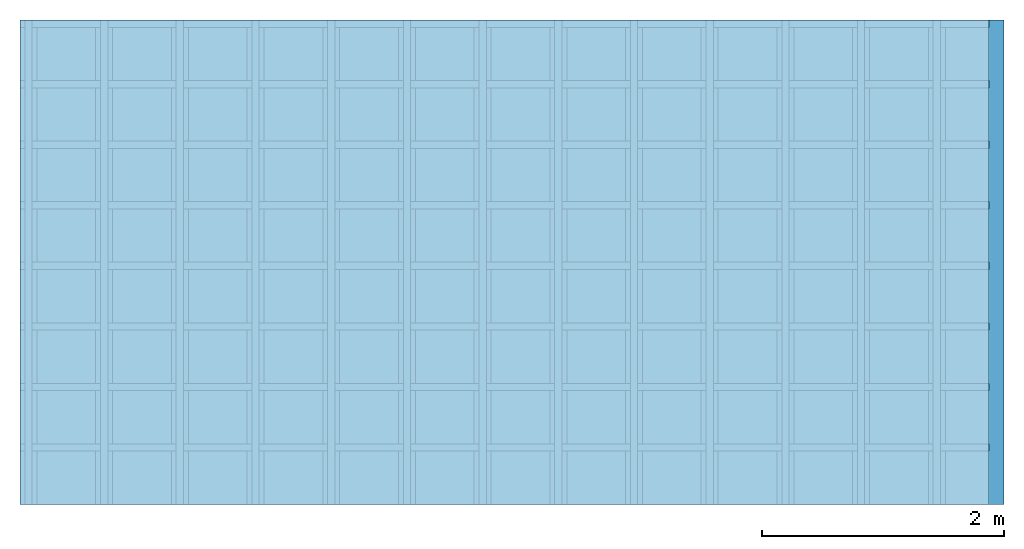
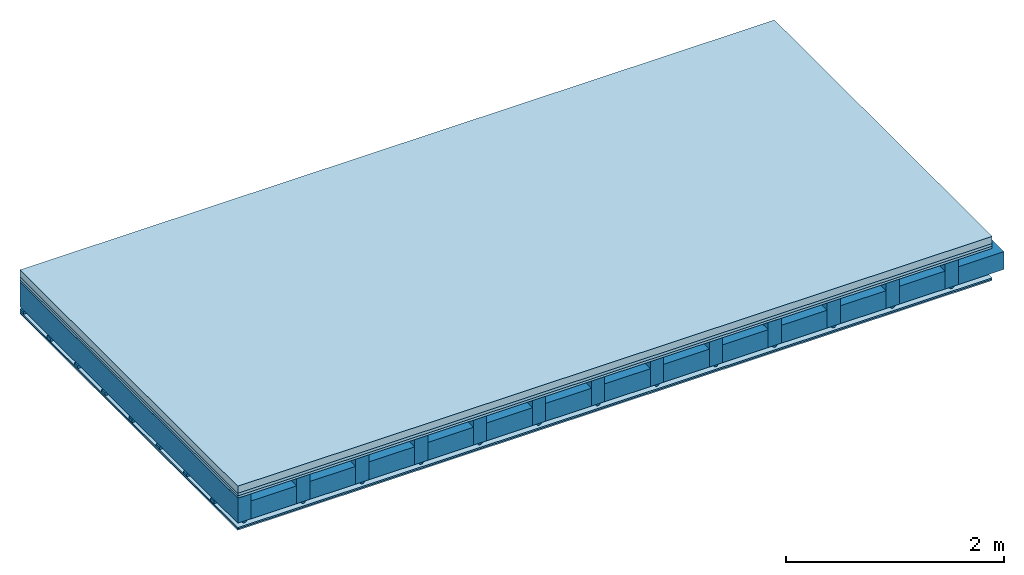
# One storey: 5 plates, 4 members, 1 element without a shape of its own.
"""IFC4 building model written with IfcOpenShell, lengths in metres."""

from ifc_helpers import new_model, si_unit, derived_unit, direction, frame, frame_2d, origin, origin_with_axes, place, context, project, spatial, polyline, rectangle, outline, extrude, material, layer, layer_set, type_object, element, aggregate, save


model = new_model("IFC4")

# Units and contexts
plan_context = context("Plan", 3, precision=1e-05, world=origin(), true_north=direction((0.0, 1.0)))
model_context = context("Model", 3, precision=1e-05, world=origin(), true_north=direction((0.0, 1.0)))
ifc_project = project(units=[si_unit("LENGTHUNIT", "METRE"), derived_unit("SOUNDPRESSUREUNIT", [(si_unit("PRESSUREUNIT", "PASCAL", prefix="MICRO"), 0)]), si_unit("ENERGYUNIT", "JOULE", prefix="MEGA"), si_unit("MASSUNIT", "GRAM", prefix="KILO"), derived_unit("THERMALTRANSMITTANCEUNIT", [(si_unit("POWERUNIT", "WATT"), 1), (si_unit("AREAUNIT", "SQUARE_METRE"), -1), (si_unit("THERMODYNAMICTEMPERATUREUNIT", "KELVIN"), -1)]), derived_unit("AREADENSITYUNIT", [(si_unit("MASSUNIT", "GRAM", prefix="KILO"), 1), (si_unit("AREAUNIT", "SQUARE_METRE"), -1)]), derived_unit("USERDEFINED", [(si_unit("ENERGYUNIT", "JOULE", prefix="MEGA"), 1), (si_unit("AREAUNIT", "SQUARE_METRE"), -1)])], contexts=[plan_context, model_context])

# Site, building, storey
site = spatial("IfcSite", under=ifc_project)
building_placement = place(None, origin())
building = spatial("IfcBuilding", under=site, at=building_placement)
storey_placement = place(building_placement, origin())
storey = spatial("IfcBuildingStorey", under=building, at=storey_placement)

# Slab, members, plates
ifc_material_1 = material(Name="Cement screed", Category="04.006")
ifc_layer_1 = layer(ifc_material_1, 0.08, Name="On-material")
ifc_material_2 = material()
ifc_layer_2 = layer(ifc_material_2, 0.03, Name="Impact sound insulation")
ifc_material_3 = material(Category="07.001")
ifc_layer_3 = layer(ifc_material_3, 0.025, Name="Sub-floor")
ifc_material_4 = material(Name="of the art")
ifc_layer_4 = layer(ifc_material_4, 0.0, Name="Bond")
ifc_layer_5 = layer(None, 0.28, Name="Supporting structure")
ifc_material_5 = material(Name="no composite action")
ifc_layer_6 = layer(ifc_material_5, 0.0, Name="Bond")
ifc_layer_7 = layer(None, 0.02, Name="Coupling")
ifc_layer_8 = layer(None, 0.03, Name="Battens / profiles")
ifc_material_6 = material(Category="03.007")
ifc_layer_9 = layer(ifc_material_6, 0.015, Name="Ceiling covering 1st layer")
ifc_layer_10 = layer(ifc_material_6, 0.015, Name="Ceiling covering layer 2")
ifc_material_7 = material(Name="Glued joints")
ifc_layer_11 = layer(ifc_material_7, 0.0, Name="Surface / treatment")
ifc_layer_set = layer_set([ifc_layer_1, ifc_layer_2, ifc_layer_3, ifc_layer_4, ifc_layer_5, ifc_layer_6, ifc_layer_7, ifc_layer_8, ifc_layer_9, ifc_layer_10, ifc_layer_11])
slab_type = type_object("IfcSlabType", Name="A0125", PredefinedType="NOTDEFINED", material=ifc_layer_set)
slab_placement = place(None, frame((0.0, 0.0, 0.0), z_axis=(0.0, 0.0, -1.0), x_axis=(1.0, 0.0, 0.0)))
slab = element("IfcSlab", 1, at=slab_placement, inside=storey, type_object=slab_type, material=ifc_layer_set, Name="Slab #1")
ifc_material_8 = material()
member_1_placement = place(slab_placement, origin())
member_1 = element("IfcMember", 2, at=member_1_placement, material=ifc_material_8, Name="Supporting structure", context=plan_context, shape_type="SweptSolid", body=[
    extrude(rectangle(XDim=0.14, YDim=0.28, at=frame_2d((0.07, 0.14), x_axis=(1.0, 0.0))), frame((0.0, 4.0, 0.135), z_axis=(0.0, -1.0, 0.0), x_axis=(1.0, 0.0, 0.0)), (0.0, 0.0, 1.0), 4.0),
    extrude(rectangle(XDim=0.14, YDim=0.28, at=frame_2d((0.07, 0.14), x_axis=(1.0, 0.0))), frame((0.625, 4.0, 0.135), z_axis=(0.0, -1.0, 0.0), x_axis=(1.0, 0.0, 0.0)), (0.0, 0.0, 1.0), 4.0),
    extrude(rectangle(XDim=0.14, YDim=0.28, at=frame_2d((0.07, 0.14), x_axis=(1.0, 0.0))), frame((1.25, 4.0, 0.135), z_axis=(0.0, -1.0, 0.0), x_axis=(1.0, 0.0, 0.0)), (0.0, 0.0, 1.0), 4.0),
    extrude(rectangle(XDim=0.14, YDim=0.28, at=frame_2d((0.07, 0.14), x_axis=(1.0, 0.0))), frame((1.875, 4.0, 0.135), z_axis=(0.0, -1.0, 0.0), x_axis=(1.0, 0.0, 0.0)), (0.0, 0.0, 1.0), 4.0),
    extrude(rectangle(XDim=0.14, YDim=0.28, at=frame_2d((0.07, 0.14), x_axis=(1.0, 0.0))), frame((2.5, 4.0, 0.135), z_axis=(0.0, -1.0, 0.0), x_axis=(1.0, 0.0, 0.0)), (0.0, 0.0, 1.0), 4.0),
    extrude(rectangle(XDim=0.14, YDim=0.28, at=frame_2d((0.07, 0.14), x_axis=(1.0, 0.0))), frame((3.125, 4.0, 0.135), z_axis=(0.0, -1.0, 0.0), x_axis=(1.0, 0.0, 0.0)), (0.0, 0.0, 1.0), 4.0),
    extrude(rectangle(XDim=0.14, YDim=0.28, at=frame_2d((0.07, 0.14), x_axis=(1.0, 0.0))), frame((3.75, 4.0, 0.135), z_axis=(0.0, -1.0, 0.0), x_axis=(1.0, 0.0, 0.0)), (0.0, 0.0, 1.0), 4.0),
    extrude(rectangle(XDim=0.14, YDim=0.28, at=frame_2d((0.07, 0.14), x_axis=(1.0, 0.0))), frame((4.375, 4.0, 0.135), z_axis=(0.0, -1.0, 0.0), x_axis=(1.0, 0.0, 0.0)), (0.0, 0.0, 1.0), 4.0),
    extrude(rectangle(XDim=0.14, YDim=0.28, at=frame_2d((0.07, 0.14), x_axis=(1.0, 0.0))), frame((5.0, 4.0, 0.135), z_axis=(0.0, -1.0, 0.0), x_axis=(1.0, 0.0, 0.0)), (0.0, 0.0, 1.0), 4.0),
    extrude(rectangle(XDim=0.14, YDim=0.28, at=frame_2d((0.07, 0.14), x_axis=(1.0, 0.0))), frame((5.625, 4.0, 0.135), z_axis=(0.0, -1.0, 0.0), x_axis=(1.0, 0.0, 0.0)), (0.0, 0.0, 1.0), 4.0),
    extrude(rectangle(XDim=0.14, YDim=0.28, at=frame_2d((0.07, 0.14), x_axis=(1.0, 0.0))), frame((6.25, 4.0, 0.135), z_axis=(0.0, -1.0, 0.0), x_axis=(1.0, 0.0, 0.0)), (0.0, 0.0, 1.0), 4.0),
    extrude(rectangle(XDim=0.14, YDim=0.28, at=frame_2d((0.07, 0.14), x_axis=(1.0, 0.0))), frame((6.875, 4.0, 0.135), z_axis=(0.0, -1.0, 0.0), x_axis=(1.0, 0.0, 0.0)), (0.0, 0.0, 1.0), 4.0),
    extrude(rectangle(XDim=0.14, YDim=0.28, at=frame_2d((0.07, 0.14), x_axis=(1.0, 0.0))), frame((7.5, 4.0, 0.135), z_axis=(0.0, -1.0, 0.0), x_axis=(1.0, 0.0, 0.0)), (0.0, 0.0, 1.0), 4.0),
])
ifc_material_9 = material()
member_2_placement = place(slab_placement, origin())
member_2 = element("IfcMember", 3, at=member_2_placement, material=ifc_material_9, Name="Cavity", context=plan_context, shape_type="SweptSolid", body=[
    extrude(rectangle(XDim=0.485, YDim=0.2, at=frame_2d((0.2425, 0.1), x_axis=(1.0, 0.0))), frame((0.14, 4.0, 0.215), z_axis=(0.0, -1.0, 0.0), x_axis=(1.0, 0.0, 0.0)), (0.0, 0.0, 1.0), 4.0),
    extrude(rectangle(XDim=0.485, YDim=0.2, at=frame_2d((0.2425, 0.1), x_axis=(1.0, 0.0))), frame((0.765, 4.0, 0.215), z_axis=(0.0, -1.0, 0.0), x_axis=(1.0, 0.0, 0.0)), (0.0, 0.0, 1.0), 4.0),
    extrude(rectangle(XDim=0.485, YDim=0.2, at=frame_2d((0.2425, 0.1), x_axis=(1.0, 0.0))), frame((1.39, 4.0, 0.215), z_axis=(0.0, -1.0, 0.0), x_axis=(1.0, 0.0, 0.0)), (0.0, 0.0, 1.0), 4.0),
    extrude(rectangle(XDim=0.485, YDim=0.2, at=frame_2d((0.2425, 0.1), x_axis=(1.0, 0.0))), frame((2.015, 4.0, 0.215), z_axis=(0.0, -1.0, 0.0), x_axis=(1.0, 0.0, 0.0)), (0.0, 0.0, 1.0), 4.0),
    extrude(rectangle(XDim=0.485, YDim=0.2, at=frame_2d((0.2425, 0.1), x_axis=(1.0, 0.0))), frame((2.64, 4.0, 0.215), z_axis=(0.0, -1.0, 0.0), x_axis=(1.0, 0.0, 0.0)), (0.0, 0.0, 1.0), 4.0),
    extrude(rectangle(XDim=0.485, YDim=0.2, at=frame_2d((0.2425, 0.1), x_axis=(1.0, 0.0))), frame((3.265, 4.0, 0.215), z_axis=(0.0, -1.0, 0.0), x_axis=(1.0, 0.0, 0.0)), (0.0, 0.0, 1.0), 4.0),
    extrude(rectangle(XDim=0.485, YDim=0.2, at=frame_2d((0.2425, 0.1), x_axis=(1.0, 0.0))), frame((3.89, 4.0, 0.215), z_axis=(0.0, -1.0, 0.0), x_axis=(1.0, 0.0, 0.0)), (0.0, 0.0, 1.0), 4.0),
    extrude(rectangle(XDim=0.485, YDim=0.2, at=frame_2d((0.2425, 0.1), x_axis=(1.0, 0.0))), frame((4.515, 4.0, 0.215), z_axis=(0.0, -1.0, 0.0), x_axis=(1.0, 0.0, 0.0)), (0.0, 0.0, 1.0), 4.0),
    extrude(rectangle(XDim=0.485, YDim=0.2, at=frame_2d((0.2425, 0.1), x_axis=(1.0, 0.0))), frame((5.14, 4.0, 0.215), z_axis=(0.0, -1.0, 0.0), x_axis=(1.0, 0.0, 0.0)), (0.0, 0.0, 1.0), 4.0),
    extrude(rectangle(XDim=0.485, YDim=0.2, at=frame_2d((0.2425, 0.1), x_axis=(1.0, 0.0))), frame((5.765, 4.0, 0.215), z_axis=(0.0, -1.0, 0.0), x_axis=(1.0, 0.0, 0.0)), (0.0, 0.0, 1.0), 4.0),
    extrude(rectangle(XDim=0.485, YDim=0.2, at=frame_2d((0.2425, 0.1), x_axis=(1.0, 0.0))), frame((6.39, 4.0, 0.215), z_axis=(0.0, -1.0, 0.0), x_axis=(1.0, 0.0, 0.0)), (0.0, 0.0, 1.0), 4.0),
    extrude(rectangle(XDim=0.485, YDim=0.2, at=frame_2d((0.2425, 0.1), x_axis=(1.0, 0.0))), frame((7.015, 4.0, 0.215), z_axis=(0.0, -1.0, 0.0), x_axis=(1.0, 0.0, 0.0)), (0.0, 0.0, 1.0), 4.0),
    extrude(rectangle(XDim=0.485, YDim=0.2, at=frame_2d((0.2425, 0.1), x_axis=(1.0, 0.0))), frame((7.64, 4.0, 0.215), z_axis=(0.0, -1.0, 0.0), x_axis=(1.0, 0.0, 0.0)), (0.0, 0.0, 1.0), 4.0),
])
ifc_material_10 = material()
member_3_placement = place(slab_placement, origin())
member_3 = element("IfcMember", 4, at=member_3_placement, material=ifc_material_10, Name="Coupling", context=plan_context, shape_type="SweptSolid", body=[
    extrude(outline(polyline([(0.0, 0.0), (0.06, 0.0), (0.04, 0.02), (0.02, 0.02), (0.0, 0.0)])), frame((0.04, 4.0, 0.415), z_axis=(0.0, -1.0, 0.0), x_axis=(1.0, 0.0, 0.0)), (0.0, 0.0, 1.0), 4.0),
    extrude(outline(polyline([(0.0, 0.0), (0.06, 0.0), (0.04, 0.02), (0.02, 0.02), (0.0, 0.0)])), frame((0.665, 4.0, 0.415), z_axis=(0.0, -1.0, 0.0), x_axis=(1.0, 0.0, 0.0)), (0.0, 0.0, 1.0), 4.0),
    extrude(outline(polyline([(0.0, 0.0), (0.06, 0.0), (0.04, 0.02), (0.02, 0.02), (0.0, 0.0)])), frame((1.29, 4.0, 0.415), z_axis=(0.0, -1.0, 0.0), x_axis=(1.0, 0.0, 0.0)), (0.0, 0.0, 1.0), 4.0),
    extrude(outline(polyline([(0.0, 0.0), (0.06, 0.0), (0.04, 0.02), (0.02, 0.02), (0.0, 0.0)])), frame((1.915, 4.0, 0.415), z_axis=(0.0, -1.0, 0.0), x_axis=(1.0, 0.0, 0.0)), (0.0, 0.0, 1.0), 4.0),
    extrude(outline(polyline([(0.0, 0.0), (0.06, 0.0), (0.04, 0.02), (0.02, 0.02), (0.0, 0.0)])), frame((2.54, 4.0, 0.415), z_axis=(0.0, -1.0, 0.0), x_axis=(1.0, 0.0, 0.0)), (0.0, 0.0, 1.0), 4.0),
    extrude(outline(polyline([(0.0, 0.0), (0.06, 0.0), (0.04, 0.02), (0.02, 0.02), (0.0, 0.0)])), frame((3.165, 4.0, 0.415), z_axis=(0.0, -1.0, 0.0), x_axis=(1.0, 0.0, 0.0)), (0.0, 0.0, 1.0), 4.0),
    extrude(outline(polyline([(0.0, 0.0), (0.06, 0.0), (0.04, 0.02), (0.02, 0.02), (0.0, 0.0)])), frame((3.79, 4.0, 0.415), z_axis=(0.0, -1.0, 0.0), x_axis=(1.0, 0.0, 0.0)), (0.0, 0.0, 1.0), 4.0),
    extrude(outline(polyline([(0.0, 0.0), (0.06, 0.0), (0.04, 0.02), (0.02, 0.02), (0.0, 0.0)])), frame((4.415, 4.0, 0.415), z_axis=(0.0, -1.0, 0.0), x_axis=(1.0, 0.0, 0.0)), (0.0, 0.0, 1.0), 4.0),
    extrude(outline(polyline([(0.0, 0.0), (0.06, 0.0), (0.04, 0.02), (0.02, 0.02), (0.0, 0.0)])), frame((5.04, 4.0, 0.415), z_axis=(0.0, -1.0, 0.0), x_axis=(1.0, 0.0, 0.0)), (0.0, 0.0, 1.0), 4.0),
    extrude(outline(polyline([(0.0, 0.0), (0.06, 0.0), (0.04, 0.02), (0.02, 0.02), (0.0, 0.0)])), frame((5.665, 4.0, 0.415), z_axis=(0.0, -1.0, 0.0), x_axis=(1.0, 0.0, 0.0)), (0.0, 0.0, 1.0), 4.0),
    extrude(outline(polyline([(0.0, 0.0), (0.06, 0.0), (0.04, 0.02), (0.02, 0.02), (0.0, 0.0)])), frame((6.29, 4.0, 0.415), z_axis=(0.0, -1.0, 0.0), x_axis=(1.0, 0.0, 0.0)), (0.0, 0.0, 1.0), 4.0),
    extrude(outline(polyline([(0.0, 0.0), (0.06, 0.0), (0.04, 0.02), (0.02, 0.02), (0.0, 0.0)])), frame((6.915, 4.0, 0.415), z_axis=(0.0, -1.0, 0.0), x_axis=(1.0, 0.0, 0.0)), (0.0, 0.0, 1.0), 4.0),
    extrude(outline(polyline([(0.0, 0.0), (0.06, 0.0), (0.04, 0.02), (0.02, 0.02), (0.0, 0.0)])), frame((7.54, 4.0, 0.415), z_axis=(0.0, -1.0, 0.0), x_axis=(1.0, 0.0, 0.0)), (0.0, 0.0, 1.0), 4.0),
])
ifc_material_11 = material()
member_4_placement = place(slab_placement, origin())
member_4 = element("IfcMember", 5, at=member_4_placement, material=ifc_material_11, Name="Battens / profiles", context=plan_context, shape_type="SweptSolid", body=[
    extrude(rectangle(XDim=0.06, YDim=0.03, at=frame_2d((0.03, 0.015), x_axis=(1.0, 0.0))), frame((0.0, 0.0, 0.435), z_axis=(1.0, 0.0, 0.0), x_axis=(0.0, 1.0, 0.0)), (0.0, 0.0, 1.0), 8.0),
    extrude(rectangle(XDim=0.06, YDim=0.03, at=frame_2d((0.03, 0.015), x_axis=(1.0, 0.0))), frame((0.0, 0.5, 0.435), z_axis=(1.0, 0.0, 0.0), x_axis=(0.0, 1.0, 0.0)), (0.0, 0.0, 1.0), 8.0),
    extrude(rectangle(XDim=0.06, YDim=0.03, at=frame_2d((0.03, 0.015), x_axis=(1.0, 0.0))), frame((0.0, 1.0, 0.435), z_axis=(1.0, 0.0, 0.0), x_axis=(0.0, 1.0, 0.0)), (0.0, 0.0, 1.0), 8.0),
    extrude(rectangle(XDim=0.06, YDim=0.03, at=frame_2d((0.03, 0.015), x_axis=(1.0, 0.0))), frame((0.0, 1.5, 0.435), z_axis=(1.0, 0.0, 0.0), x_axis=(0.0, 1.0, 0.0)), (0.0, 0.0, 1.0), 8.0),
    extrude(rectangle(XDim=0.06, YDim=0.03, at=frame_2d((0.03, 0.015), x_axis=(1.0, 0.0))), frame((0.0, 2.0, 0.435), z_axis=(1.0, 0.0, 0.0), x_axis=(0.0, 1.0, 0.0)), (0.0, 0.0, 1.0), 8.0),
    extrude(rectangle(XDim=0.06, YDim=0.03, at=frame_2d((0.03, 0.015), x_axis=(1.0, 0.0))), frame((0.0, 2.5, 0.435), z_axis=(1.0, 0.0, 0.0), x_axis=(0.0, 1.0, 0.0)), (0.0, 0.0, 1.0), 8.0),
    extrude(rectangle(XDim=0.06, YDim=0.03, at=frame_2d((0.03, 0.015), x_axis=(1.0, 0.0))), frame((0.0, 3.0, 0.435), z_axis=(1.0, 0.0, 0.0), x_axis=(0.0, 1.0, 0.0)), (0.0, 0.0, 1.0), 8.0),
    extrude(rectangle(XDim=0.06, YDim=0.03, at=frame_2d((0.03, 0.015), x_axis=(1.0, 0.0))), frame((0.0, 3.5, 0.435), z_axis=(1.0, 0.0, 0.0), x_axis=(0.0, 1.0, 0.0)), (0.0, 0.0, 1.0), 8.0),
])
plate_1_placement = place(slab_placement, origin())
plate_1 = element("IfcPlate", 6, at=plate_1_placement, material=ifc_material_1, Name="On-material", context=plan_context, shape_type="SweptSolid", body=[
    extrude(rectangle(XDim=8.0, YDim=4.0, at=frame_2d((4.0, 2.0), x_axis=(1.0, 0.0))), origin_with_axes(), (0.0, 0.0, 1.0), 0.08),
])
plate_2_placement = place(slab_placement, origin())
plate_2 = element("IfcPlate", 7, at=plate_2_placement, material=ifc_material_2, Name="Impact sound insulation", context=plan_context, shape_type="SweptSolid", body=[
    extrude(rectangle(XDim=8.0, YDim=4.0, at=frame_2d((4.0, 2.0), x_axis=(1.0, 0.0))), frame((0.0, 0.0, 0.08), z_axis=(0.0, 0.0, 1.0), x_axis=(1.0, 0.0, 0.0)), (0.0, 0.0, 1.0), 0.03),
])
plate_3_placement = place(slab_placement, origin())
plate_3 = element("IfcPlate", 8, at=plate_3_placement, material=ifc_material_3, Name="Sub-floor", context=plan_context, shape_type="SweptSolid", body=[
    extrude(rectangle(XDim=8.0, YDim=4.0, at=frame_2d((4.0, 2.0), x_axis=(1.0, 0.0))), frame((0.0, 0.0, 0.11), z_axis=(0.0, 0.0, 1.0), x_axis=(1.0, 0.0, 0.0)), (0.0, 0.0, 1.0), 0.025),
])
plate_4_placement = place(slab_placement, origin())
plate_4 = element("IfcPlate", 9, at=plate_4_placement, material=ifc_material_6, Name="Ceiling covering 1st layer", context=plan_context, shape_type="SweptSolid", body=[
    extrude(rectangle(XDim=8.0, YDim=4.0, at=frame_2d((4.0, 2.0), x_axis=(1.0, 0.0))), frame((0.0, 0.0, 0.465), z_axis=(0.0, 0.0, 1.0), x_axis=(1.0, 0.0, 0.0)), (0.0, 0.0, 1.0), 0.015),
])
plate_5_placement = place(slab_placement, origin())
plate_5 = element("IfcPlate", 10, at=plate_5_placement, material=ifc_material_6, Name="Ceiling covering layer 2", context=plan_context, shape_type="SweptSolid", body=[
    extrude(rectangle(XDim=8.0, YDim=4.0, at=frame_2d((4.0, 2.0), x_axis=(1.0, 0.0))), frame((0.0, 0.0, 0.48), z_axis=(0.0, 0.0, 1.0), x_axis=(1.0, 0.0, 0.0)), (0.0, 0.0, 1.0), 0.015),
])
aggregate(slab, [plate_1, plate_2, plate_3, member_1, member_2, member_3, member_4, plate_4, plate_5])

save(model, "model.ifc")
